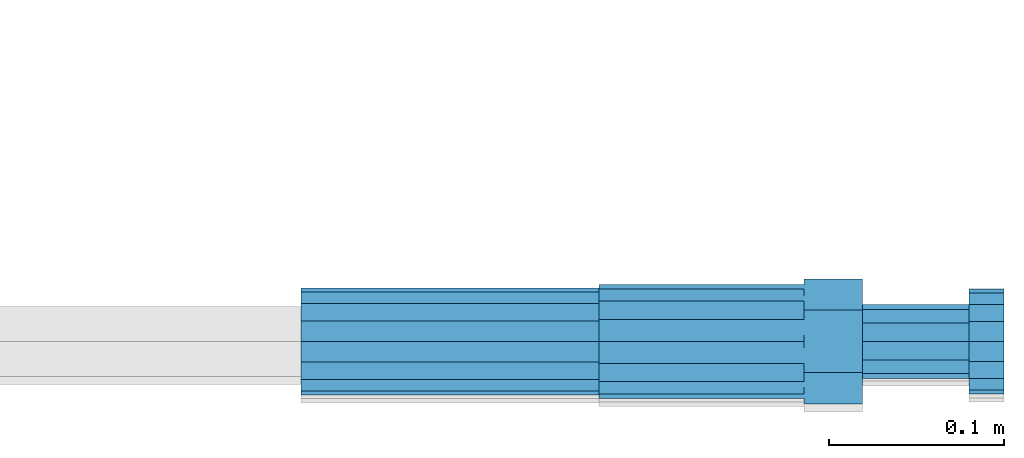
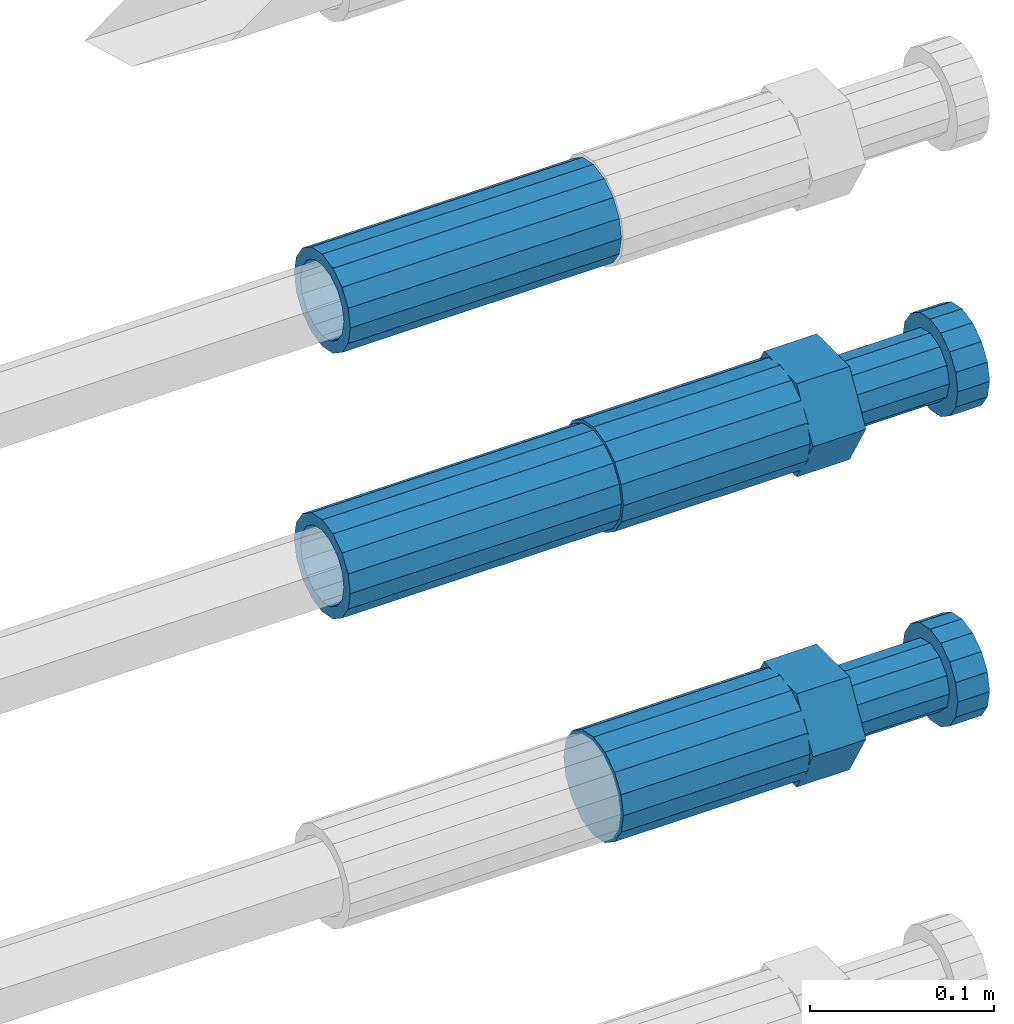
# One storey, part 106 of 119: 4 beams.
"""IFC2X3 building model written with IfcOpenShell, lengths in millimetres."""

import ifcopenshell
import ifcopenshell.guid

model = None  # the IFC model being written
_history = None  # IfcOwnerHistory: only IFC2X3 demands one
_inside = {}  # id of a spatial element -> (the spatial element, [elements in it])
_under = {}  # id of a project, library or spatial element -> (it, [spatial elements below it])
_declared = {}  # id of a project -> (the project, [libraries it declares])
_typed = {}  # id of a type object -> (the type object, [elements of that type])
_made_of = {}  # id of a material, layer set ... -> (it, [elements and type objects made of it])


def new_model(schema):
    """Start an empty IFC model of exactly this schema.

    Asked for "IFC4X3", IfcOpenShell would pick the latest addendum, in which some entities
    have other attributes; the version numbers below select the first issue.
    IFC2X3 requires an IfcOwnerHistory on every rooted entity: one is made here for all.
    """
    global model, _history
    if schema == "IFC4X3":
        model = ifcopenshell.file(schema_version=(4, 3, 0, 0))
    else:
        model = ifcopenshell.file(schema=schema)
    _inside.clear()
    _under.clear()
    _declared.clear()
    _typed.clear()
    _made_of.clear()
    _history = None
    if model.schema == "IFC2X3":
        org = make("IfcOrganization", Name="unknown")
        user = make(
            "IfcPersonAndOrganization",
            ThePerson=make("IfcPerson", FamilyName="unknown"),
            TheOrganization=org,
        )
        app = make(
            "IfcApplication",
            ApplicationDeveloper=org,
            Version="unknown",
            ApplicationFullName="unknown",
            ApplicationIdentifier="unknown",
        )
        _history = make(
            "IfcOwnerHistory",
            OwningUser=user,
            OwningApplication=app,
            ChangeAction="ADDED",
            CreationDate=0,
        )
    return model


def make(cls, **values):
    """One entity of the class cls with the attributes given. An attribute that is None is left unset."""
    return model.create_entity(
        cls, **{name: value for name, value in values.items() if value is not None}
    )


def rooted(cls, **values):
    """An entity with a GlobalId (a new one), such as an element, a storey or a relation."""
    return make(cls, GlobalId=ifcopenshell.guid.new(), OwnerHistory=_history, **values)


def si_unit(unit_type, name, prefix=None):
    """IfcSIUnit, for example si_unit("LENGTHUNIT", "METRE", prefix="MILLI")."""
    return make("IfcSIUnit", UnitType=unit_type, Prefix=prefix, Name=name)


def assignment(units):
    """IfcUnitAssignment: the units of a project."""
    return None if units is None else make("IfcUnitAssignment", Units=units)


def point(xyz):
    """IfcCartesianPoint."""
    return None if xyz is None else make("IfcCartesianPoint", Coordinates=xyz)


def direction(xyz):
    """IfcDirection."""
    return None if xyz is None else make("IfcDirection", DirectionRatios=xyz)


def frame(location, z_axis=None, x_axis=None):
    """IfcAxis2Placement3D, a coordinate frame: its origin and axes. An axis left out is left unset."""
    return make(
        "IfcAxis2Placement3D",
        Location=point(location),
        Axis=direction(z_axis),
        RefDirection=direction(x_axis),
    )


def origin_with_axes():
    """The frame at (0, 0, 0) with the z axis (0, 0, 1) and the x axis (1, 0, 0) written out."""
    return frame((0.0, 0.0, 0.0), z_axis=(0.0, 0.0, 1.0), x_axis=(1.0, 0.0, 0.0))


def place(relative_to, where):
    """IfcLocalPlacement: puts the frame where relative to a parent placement (None: the world)."""
    return make(
        "IfcLocalPlacement", PlacementRelTo=relative_to, RelativePlacement=where
    )


def context(
    kind, dimensions, precision=None, world=None, true_north=None, identifier=None
):
    """IfcGeometricRepresentationContext, for example the 3D "Model" context."""
    return make(
        "IfcGeometricRepresentationContext",
        ContextIdentifier=identifier,
        ContextType=kind,
        CoordinateSpaceDimension=dimensions,
        Precision=precision,
        WorldCoordinateSystem=world,
        TrueNorth=true_north,
    )


def subcontext(parent, identifier, kind, view, scale=None):
    """IfcGeometricRepresentationSubContext, for example "Body" below "Model"."""
    return make(
        "IfcGeometricRepresentationSubContext",
        ContextIdentifier=identifier,
        ContextType=kind,
        ParentContext=parent,
        TargetScale=scale,
        TargetView=view,
    )


def project(units=None, contexts=None):
    """IfcProject with its units and contexts."""
    return rooted(
        "IfcProject",
        Name="project",
        RepresentationContexts=contexts,
        UnitsInContext=assignment(units),
    )


def spatial(cls, under=None, at=None, **own):
    """A site, building, storey or space (cls), placed at a placement, below another one or the project."""
    s = rooted(cls, ObjectPlacement=at, **own)
    if under is not None:
        _under.setdefault(under.id(), (under, []))[1].append(s)
    return s


def faces_of(points, faces, orient=None, outer=None):
    """IfcFace entities. A face is a list of loops; a loop is a list of indices into points, from 0.

    orient and outer hold one flag for each loop. By default every Orientation is true, the
    first loop of a face is its IfcFaceOuterBound and the others are IfcFaceBound.
    """
    made = []
    for i, loops in enumerate(faces):
        bounds = []
        for j, loop in enumerate(loops):
            is_outer = j == 0 if outer is None else outer[i][j]
            bounds.append(
                make(
                    "IfcFaceOuterBound" if is_outer else "IfcFaceBound",
                    Bound=make("IfcPolyLoop", Polygon=[points[k] for k in loop]),
                    Orientation=True if orient is None else orient[i][j],
                )
            )
        made.append(make("IfcFace", Bounds=bounds))
    return made


def faceted_brep(points, faces, orient=None, outer=None, voids=None):
    """IfcFacetedBrep: a solid bounded by flat faces; with voids (closed shells), ...WithVoids."""
    shared = [point(p) for p in points]
    hull = make("IfcClosedShell", CfsFaces=faces_of(shared, faces, orient, outer))
    if voids is None:
        return make("IfcFacetedBrep", Outer=hull)
    return make(
        "IfcFacetedBrepWithVoids",
        Outer=hull,
        Voids=[
            make(cls, CfsFaces=faces_of(shared, fs, o, b)) for cls, fs, o, b in voids
        ],
    )


def shape(context_of_items, identifier, shape_type, items):
    """IfcShapeRepresentation: the items that make up one representation, for example the "Body"."""
    return make(
        "IfcShapeRepresentation",
        ContextOfItems=context_of_items,
        RepresentationIdentifier=identifier,
        RepresentationType=shape_type,
        Items=items,
    )


def material(Name=None, Category=None):
    """IfcMaterial."""
    return make("IfcMaterial", Name=Name, Category=Category)


def made_of(thing, what):
    """Note that an element or type object is made of a material, layer set ...; save() writes the relation."""
    if what is not None:
        _made_of.setdefault(what.id(), (what, []))[1].append(thing)
    return thing


def type_object(cls, material=None, **own):
    """A type object (cls), such as IfcWallType, which elements share."""
    return made_of(rooted(cls, **own), material)


def element(
    cls,
    number,
    at=None,
    inside=None,
    cuts=None,
    type_object=None,
    material=None,
    context=None,
    identifier="Body",
    shape_type=None,
    held_by="IfcProductDefinitionShape",
    body=None,
    shapes=None,
    **own,
):
    """One element of the class cls, such as IfcWall. Its Tag is "e" and its number.

    at: its placement. inside: the storey or other place that contains it. cuts: it is an
    opening in that element (IfcRelVoidsElement). A single representation is given by context,
    identifier, shape_type and body (its items); several are given by shapes. held_by: the class
    of the entity that holds the representations. save() writes the other relations.
    """
    e = rooted(cls, Tag="e%d" % number, ObjectPlacement=at, **own)
    if body is not None:
        shapes = [shape(context, identifier, shape_type, body)]
    if shapes is not None:
        e.Representation = make(held_by, Representations=shapes)
    if inside is not None:
        _inside.setdefault(inside.id(), (inside, []))[1].append(e)
    if cuts is not None:
        rooted(
            "IfcRelVoidsElement", RelatingBuildingElement=cuts, RelatedOpeningElement=e
        )
    if type_object is not None:
        _typed.setdefault(type_object.id(), (type_object, []))[1].append(e)
    return made_of(e, material)


def aggregate(whole, parts):
    """IfcRelAggregates: a whole, such as a stair, and the parts it consists of."""
    return rooted("IfcRelAggregates", RelatingObject=whole, RelatedObjects=parts)


def save(model, path):
    """Write the relations noted so far, then the file.

    IfcRelAggregates (storeys below a building ...), IfcRelContainedInSpatialStructure (elements
    in a storey), IfcRelDefinesByType, IfcRelAssociatesMaterial and IfcRelDeclares: one each for
    every whole, place, type object, material and project.
    """
    for whole, parts in _under.values():
        aggregate(whole, parts)
    for where, things in _inside.values():
        rooted(
            "IfcRelContainedInSpatialStructure",
            RelatedElements=things,
            RelatingStructure=where,
        )
    for kind, things in _typed.values():
        rooted("IfcRelDefinesByType", RelatedObjects=things, RelatingType=kind)
    for what, things in _made_of.values():
        rooted("IfcRelAssociatesMaterial", RelatedObjects=things, RelatingMaterial=what)
    for by, libraries in _declared.values():
        rooted("IfcRelDeclares", RelatingContext=by, RelatedDefinitions=libraries)
    model.write(path)


model = new_model("IFC2X3")

# Units and contexts
model_context = context("Model", 3, precision=1e-05, world=origin_with_axes())
body_context = subcontext(model_context, "Body", "Model", "MODEL_VIEW")
ifc_project = project(units=[si_unit("LENGTHUNIT", "METRE", prefix="MILLI"), si_unit("AREAUNIT", "SQUARE_METRE"), si_unit("VOLUMEUNIT", "CUBIC_METRE"), si_unit("MASSUNIT", "GRAM", prefix="KILO"), si_unit("TIMEUNIT", "SECOND"), si_unit("PLANEANGLEUNIT", "RADIAN"), si_unit("SOLIDANGLEUNIT", "STERADIAN"), si_unit("THERMODYNAMICTEMPERATUREUNIT", "DEGREE_CELSIUS"), si_unit("LUMINOUSINTENSITYUNIT", "LUMEN")], contexts=[model_context])

# Site, building, storey
site_placement = place(None, origin_with_axes())
site = spatial("IfcSite", under=ifc_project, at=site_placement, CompositionType="ELEMENT")
building_placement = place(site_placement, origin_with_axes())
building = spatial("IfcBuilding", under=site, at=building_placement, Name="Undefined", CompositionType="ELEMENT")
storey_placement = place(building_placement, origin_with_axes())
storey = spatial("IfcBuildingStorey", under=building, at=storey_placement, Name="Undefined", CompositionType="ELEMENT", Elevation=0.0)

# Beams
ifc_material = material(Name="STEEL/S275")
beam_type_1 = type_object("IfcBeamType", PredefinedType="NOTDEFINED")
beam_1_placement = place(storey_placement, frame((2039349.03023304, 6205102.98994599, 21913.4694122944), z_axis=(0.0, 0.0, 1.0), x_axis=(1.0, 0.0, 0.0)))
element("IfcBeam", 1, at=beam_1_placement, inside=storey, type_object=beam_type_1, material=ifc_material, Name="AG40N", context=body_context, shape_type="Brep", body=[
    faceted_brep([(1.62981450557709e-09, -23.4999999990687, 0.0), (7.45058059692383e-09, -21.7111690142192, 8.99306066057534), (170.000002125278, -21.711168999318, 8.99306066022245), (170.000002127141, -23.4999999844003, -3.66071617463604e-10), (4.65661287307739e-09, -16.6170093587134, 16.6170093578889), (170.000002122484, -16.6170093440451, 16.6170093575288), (1.86264514923096e-09, -8.99306066217832, 21.7111690140277), (170.000002118759, -8.99306064750999, 21.7111690136603), (2.3283064365387e-10, 9.31322574615479e-10, 23.5), (170.000002114102, 1.28056854009628e-08, 23.4999999996485), (-6.51925802230835e-09, 8.99306065868586, 21.7111690140241), (170.00000211224, 8.99306067335419, 21.7111690136639), (-7.45058059692383e-09, 16.6170093561523, 16.6170093578853), (170.000002109446, 16.6170093708206, 16.6170093575324), (-9.31322574615479e-09, 21.711169013055, 8.99306066057534), (170.000002108514, 21.7111690277234, 8.99306066022245), (-1.16415321826935e-09, 23.5000000009313, 0.0), (170.000002108514, 23.5000000144355, -3.66071617463604e-10), (-8.38190317153931e-09, 21.7111690151505, -8.99306066059444), (170.000002110377, 21.7111690300517, -8.9930606609546), (-5.58793544769287e-09, 16.6170093598776, -16.6170093579008), (170.000002113171, 16.6170093745459, -16.6170093582609), (-9.31322574615479e-10, 8.99306066334248, -21.7111690140396), (170.000002115965, 8.99306067801081, -21.7111690143961), (2.3283064365387e-10, 9.31322574615479e-10, -23.5), (170.00000211969, 1.7927959561348e-08, -23.5000000003843), (5.58793544769287e-09, -8.99306065752171, -21.7111690140396), (170.000002123415, -8.99306064285338, -21.7111690143961), (8.38190317153931e-09, -16.6170093549881, -16.6170093579008), (170.000002125278, -16.6170093403198, -16.6170093582646), (9.31322574615479e-09, -21.7111690121237, -8.99306066059444), (170.000002127141, -21.7111689972226, -8.9930606609546), (1.11758708953857e-08, -30.4999999990687, -9.54969436861575e-12), (1.30385160446167e-08, -28.1783257392235, -11.6718446871514), (170.000002129003, -28.1783257243223, -11.6718446875116), (170.000002129935, -30.4999999841675, -3.66071617463604e-10), (1.02445483207703e-08, -21.5667568228673, -21.5667568262129), (170.000002128072, -21.566756808199, -21.5667568265694), (7.45058059692383e-09, -11.6718446831219, -28.1783257416196), (170.000002125278, -11.6718446684536, -28.1783257419834), (3.72529029846191e-09, 3.95812094211578e-09, -30.5000000000277), (170.00000211969, 1.83936208486557e-08, -30.5000000003879), (-9.31322574615479e-10, 11.6718446905725, -28.1783257416232), (170.000002115965, 11.6718447052408, -28.1783257419797), (-6.51925802230835e-09, 21.5667568286881, -21.5667568262093), (170.000002110377, 21.5667568433564, -21.5667568265694), (-9.31322574615479e-09, 28.178325742716, -11.6718446871478), (170.000002108514, 28.1783257573843, -11.6718446875079), (-1.21071934700012e-08, 30.5, -5.91171556152403e-12), (170.000002106652, 30.5000000144355, -3.62433638656512e-10), (-1.21071934700012e-08, 28.1783257401548, 11.6718446871359), (170.00000210572, 28.1783257548232, 11.6718446867794), (-1.02445483207703e-08, 21.5667568240315, 21.5667568261974), (170.000002107583, 21.566756838467, 21.5667568258409), (-7.45058059692383e-09, 11.671844684286, 28.1783257416041), (170.000002110377, 11.6718446989544, 28.178325741244), (-2.79396772384644e-09, -2.56113708019257e-09, 30.5000000000159), (170.000002114102, 1.18743628263474e-08, 30.4999999996558), (1.86264514923096e-09, -11.6718446896411, 28.1783257416114), (170.000002118759, -11.67184467474, 28.178325741244), (7.45058059692383e-09, -21.5667568275239, 21.5667568261974), (170.000002123415, -21.5667568126228, 21.5667568258373), (1.02445483207703e-08, -28.1783257415518, 11.6718446871359), (170.000002127141, -28.1783257271163, 11.6718446867794)], [[[0, 1, 2, 3]], [[1, 4, 5, 2]], [[4, 6, 7, 5]], [[6, 8, 9, 7]], [[8, 10, 11, 9]], [[10, 12, 13, 11]], [[12, 14, 15, 13]], [[14, 16, 17, 15]], [[16, 18, 19, 17]], [[18, 20, 21, 19]], [[20, 22, 23, 21]], [[22, 24, 25, 23]], [[24, 26, 27, 25]], [[26, 28, 29, 27]], [[28, 30, 31, 29]], [[30, 0, 3, 31]], [[32, 33, 34, 35]], [[33, 36, 37, 34]], [[36, 38, 39, 37]], [[38, 40, 41, 39]], [[40, 42, 43, 41]], [[42, 44, 45, 43]], [[44, 46, 47, 45]], [[46, 48, 49, 47]], [[48, 50, 51, 49]], [[50, 52, 53, 51]], [[52, 54, 55, 53]], [[54, 56, 57, 55]], [[56, 58, 59, 57]], [[58, 60, 61, 59]], [[60, 62, 63, 61]], [[62, 32, 35, 63]], [[37, 39, 41, 43, 45, 47, 49, 51, 53, 55, 57, 59, 61, 63, 35, 34], [5, 7, 9, 11, 13, 15, 17, 19, 21, 23, 25, 27, 29, 31, 3, 2]], [[62, 60, 58, 56, 54, 52, 50, 48, 46, 44, 42, 40, 38, 36, 33, 32], [30, 28, 26, 24, 22, 20, 18, 16, 14, 12, 10, 8, 6, 4, 1, 0]]]),
])
beam_2_placement = place(storey_placement, frame((2039349.03023304, 6205102.98994599, 22089.4694122944), z_axis=(0.0, 0.0, 1.0), x_axis=(1.0, 0.0, 0.0)))
element("IfcBeam", 2, at=beam_2_placement, inside=storey, type_object=beam_type_1, material=ifc_material, Name="AG40N", context=body_context, shape_type="Brep", body=[
    faceted_brep([(1.62981450557709e-09, -23.4999999990687, 0.0), (7.45058059692383e-09, -21.7111690142192, 8.99306066057534), (170.000002125278, -21.711168999318, 8.99306066022245), (170.000002127141, -23.4999999844003, -3.66071617463604e-10), (4.65661287307739e-09, -16.6170093587134, 16.6170093578889), (170.000002122484, -16.6170093440451, 16.6170093575288), (1.86264514923096e-09, -8.99306066217832, 21.7111690140277), (170.000002118759, -8.99306064750999, 21.7111690136603), (2.3283064365387e-10, 9.31322574615479e-10, 23.5), (170.000002114102, 1.28056854009628e-08, 23.4999999996485), (-6.51925802230835e-09, 8.99306065868586, 21.7111690140241), (170.00000211224, 8.99306067335419, 21.7111690136639), (-7.45058059692383e-09, 16.6170093561523, 16.6170093578853), (170.000002109446, 16.6170093708206, 16.6170093575324), (-9.31322574615479e-09, 21.711169013055, 8.99306066057534), (170.000002108514, 21.7111690277234, 8.99306066022245), (-1.16415321826935e-09, 23.5000000009313, 0.0), (170.000002108514, 23.5000000144355, -3.66071617463604e-10), (-8.38190317153931e-09, 21.7111690151505, -8.99306066059444), (170.000002110377, 21.7111690300517, -8.9930606609546), (-5.58793544769287e-09, 16.6170093598776, -16.6170093579008), (170.000002113171, 16.6170093745459, -16.6170093582609), (-9.31322574615479e-10, 8.99306066334248, -21.7111690140396), (170.000002115965, 8.99306067801081, -21.7111690143961), (2.3283064365387e-10, 9.31322574615479e-10, -23.5), (170.00000211969, 1.7927959561348e-08, -23.5000000003843), (5.58793544769287e-09, -8.99306065752171, -21.7111690140396), (170.000002123415, -8.99306064285338, -21.7111690143961), (8.38190317153931e-09, -16.6170093549881, -16.6170093579008), (170.000002125278, -16.6170093403198, -16.6170093582646), (9.31322574615479e-09, -21.7111690121237, -8.99306066059444), (170.000002127141, -21.7111689972226, -8.9930606609546), (1.11758708953857e-08, -30.4999999990687, -9.54969436861575e-12), (1.30385160446167e-08, -28.1783257392235, -11.6718446871514), (170.000002129003, -28.1783257243223, -11.6718446875116), (170.000002129935, -30.4999999841675, -3.66071617463604e-10), (1.02445483207703e-08, -21.5667568228673, -21.5667568262129), (170.000002128072, -21.566756808199, -21.5667568265694), (7.45058059692383e-09, -11.6718446831219, -28.1783257416196), (170.000002125278, -11.6718446684536, -28.1783257419834), (3.72529029846191e-09, 3.95812094211578e-09, -30.5000000000277), (170.00000211969, 1.83936208486557e-08, -30.5000000003879), (-9.31322574615479e-10, 11.6718446905725, -28.1783257416232), (170.000002115965, 11.6718447052408, -28.1783257419797), (-6.51925802230835e-09, 21.5667568286881, -21.5667568262093), (170.000002110377, 21.5667568433564, -21.5667568265694), (-9.31322574615479e-09, 28.178325742716, -11.6718446871478), (170.000002108514, 28.1783257573843, -11.6718446875079), (-1.21071934700012e-08, 30.5, -5.91171556152403e-12), (170.000002106652, 30.5000000144355, -3.62433638656512e-10), (-1.21071934700012e-08, 28.1783257401548, 11.6718446871359), (170.00000210572, 28.1783257548232, 11.6718446867794), (-1.02445483207703e-08, 21.5667568240315, 21.5667568261974), (170.000002107583, 21.566756838467, 21.5667568258409), (-7.45058059692383e-09, 11.671844684286, 28.1783257416041), (170.000002110377, 11.6718446989544, 28.178325741244), (-2.79396772384644e-09, -2.56113708019257e-09, 30.5000000000159), (170.000002114102, 1.18743628263474e-08, 30.4999999996558), (1.86264514923096e-09, -11.6718446896411, 28.1783257416114), (170.000002118759, -11.67184467474, 28.178325741244), (7.45058059692383e-09, -21.5667568275239, 21.5667568261974), (170.000002123415, -21.5667568126228, 21.5667568258373), (1.02445483207703e-08, -28.1783257415518, 11.6718446871359), (170.000002127141, -28.1783257271163, 11.6718446867794)], [[[0, 1, 2, 3]], [[1, 4, 5, 2]], [[4, 6, 7, 5]], [[6, 8, 9, 7]], [[8, 10, 11, 9]], [[10, 12, 13, 11]], [[12, 14, 15, 13]], [[14, 16, 17, 15]], [[16, 18, 19, 17]], [[18, 20, 21, 19]], [[20, 22, 23, 21]], [[22, 24, 25, 23]], [[24, 26, 27, 25]], [[26, 28, 29, 27]], [[28, 30, 31, 29]], [[30, 0, 3, 31]], [[32, 33, 34, 35]], [[33, 36, 37, 34]], [[36, 38, 39, 37]], [[38, 40, 41, 39]], [[40, 42, 43, 41]], [[42, 44, 45, 43]], [[44, 46, 47, 45]], [[46, 48, 49, 47]], [[48, 50, 51, 49]], [[50, 52, 53, 51]], [[52, 54, 55, 53]], [[54, 56, 57, 55]], [[56, 58, 59, 57]], [[58, 60, 61, 59]], [[60, 62, 63, 61]], [[62, 32, 35, 63]], [[37, 39, 41, 43, 45, 47, 49, 51, 53, 55, 57, 59, 61, 63, 35, 34], [5, 7, 9, 11, 13, 15, 17, 19, 21, 23, 25, 27, 29, 31, 3, 2]], [[62, 60, 58, 56, 54, 52, 50, 48, 46, 44, 42, 40, 38, 36, 33, 32], [30, 28, 26, 24, 22, 20, 18, 16, 14, 12, 10, 8, 6, 4, 1, 0]]]),
])
beam_type_2 = type_object("IfcBeamType", Name="ROD65", PredefinedType="NOTDEFINED")
beam_3_placement = place(storey_placement, frame((2039519.03023304, 6205102.98994599, 21707.9894143809), z_axis=(0.0, 0.0, 1.0), x_axis=(1.0, 0.0, 0.0)))
element("IfcBeam", 3, at=beam_3_placement, inside=storey, type_object=beam_type_2, material=ifc_material, Name="AGB40", ObjectType="ROD65", context=body_context, shape_type="Brep", body=[
    faceted_brep([(116.999999999069, 17.8249999252148, 30.8738056446964), (116.999999998137, 22.0056957420893, 23.632628078838), (116.999999999069, 12.4372115600854, 30.0260848066173), (116.999999999069, 8.17543111252598, 30.8738056446964), (117.000000000931, -17.8250000746921, 30.8738056446964), (150.200000001118, -17.8250000723638, 30.8738056446964), (150.199999999255, 17.8249999275431, 30.8738056446964), (117.000000000931, -8.17543109622784, 30.8738056446964), (117.000000001863, -22.0056959956419, 23.6326278985034), (117.000000000931, -12.4372115437873, 30.0260848066173), (117.000000001863, -35.6500000746455, -2.18278728425503e-10), (150.200000002049, -35.6500000723172, -2.18278728425503e-10), (117.000000001863, -30.8443149488885, 8.32369080289209), (117.000000001863, -30.8443149488885, -8.32369080355784), (117.000000002794, -32.4999999918509, 0.0), (117.000000000931, -17.8250000746921, -30.873805645133), (150.200000001118, -17.8250000723638, -30.873805645133), (117.000000001863, -22.0056959961075, -23.6326278982269), (117.000000000931, -8.17543109389953, -30.873805645133), (117.000000000931, -12.4372115437873, -30.0260848066173), (116.999999999069, 17.8249999252148, -30.873805645133), (150.199999999255, 17.8249999275431, -30.873805645133), (116.999999999069, 8.17543111019768, -30.873805645133), (116.999999999069, 12.4372115600854, -30.0260848066173), (116.999999998137, 22.005695742555, -23.6326280785652), (116.999999998137, 35.6499999251682, -2.18278728425503e-10), (150.199999998324, 35.6499999277294, -2.18278728425503e-10), (116.999999998137, 30.8443150522653, -8.32369036550881), (116.999999997206, 32.5000000081491, 0.0), (116.999999998137, 30.8443150522653, 8.32369036483942), (1.86264514923096e-09, -22.9809703885112, 22.9809703885621), (1.86264514923096e-09, -30.0260848065373, 12.4372115518672), (117.000000001863, -30.0260847983882, 12.4372115518672), (117.000000001863, -22.9809703803621, 22.9809703885621), (-1.86264514923096e-09, 22.9809703885112, -22.9809703885621), (-1.86264514923096e-09, 30.0260848065373, -12.4372115518672), (116.999999998137, 30.0260848146863, -12.4372115518672), (116.999999998137, 22.9809703966603, -22.9809703885621), (1.86264514923096e-09, -30.0260848065373, -12.4372115518672), (1.86264514923096e-09, -22.9809703885112, -22.9809703885621), (117.000000001863, -22.9809703803621, -22.9809703885621), (117.000000001863, -30.0260847983882, -12.4372115518672), (9.31322574615479e-10, -12.4372115519363, 30.0260848066173), (0.0, 0.0, 32.5), (-9.31322574615479e-10, 12.4372115519363, 30.0260848066173), (-1.86264514923096e-09, 22.9809703885112, 22.9809703885621), (-1.86264514923096e-09, 30.0260848065373, 12.4372115518672), (-2.79396772384644e-09, 32.5, 0.0), (-9.31322574615479e-10, 12.4372115519363, -30.0260848066173), (0.0, 0.0, -32.5), (9.31322574615479e-10, -12.4372115519363, -30.0260848066173), (2.79396772384644e-09, -32.5, 0.0), (116.999999998137, 22.9809703966603, 22.9809703885621), (116.999999998137, 30.0260848146863, 12.4372115518672), (117.0, 8.14907252788544e-09, -32.5), (117.0, 8.14907252788544e-09, 32.5), (150.200000000186, -10.5000000959262, 18.1865334791873), (150.199999999255, -9.59262251853943e-08, 20.9999999997126), (150.199999998324, 10.4999999040738, 18.1865334791873), (150.199999997392, 18.1865333835594, 10.4999999997126), (150.199999997392, 20.9999999040738, -2.87400325760245e-10), (150.199999997392, 18.1865333835594, -10.5000000002874), (150.199999998324, 10.4999999040738, -18.1865334797621), (150.199999999255, -9.59262251853943e-08, -21.0000000002874), (150.200000000186, -10.5000000959262, -18.1865334797621), (150.200000000186, -18.1865335754119, -10.5000000002874), (150.200000001118, -21.0000000959262, -2.87400325760245e-10), (150.200000000186, -18.1865335754119, 10.4999999997126), (210.979999999516, 10.4999999082647, 18.1865334791873), (210.979999999516, -9.17352735996246e-08, 20.9999999997126), (210.979999997653, 18.1865333877504, 10.4999999997126), (210.979999997653, 20.9999999082647, -2.87400325760245e-10), (210.979999997653, 18.1865333877504, -10.5000000002874), (210.979999999516, 10.4999999082647, -18.1865334797621), (210.979999999516, -9.17352735996246e-08, -21.0000000002874), (210.979999999516, -10.5000000917353, -18.1865334797621), (210.980000000447, -18.1865335712209, -10.5000000002874), (210.980000001378, -21.0000000917353, -2.87400325760245e-10), (210.980000000447, -18.1865335712209, 10.4999999997126), (210.979999999516, -10.5000000917353, 18.1865334791873), (211.001368402503, -27.7269939335529, -11.4911163272045), (211.003082515672, -21.2238095656503, -21.2238154190527), (231.002518340945, -21.2131946226582, -21.2132004554769), (231.000804228708, -27.7163789905608, -11.4805013636287), (211.001368415542, -11.4911086384673, -27.7269970399575), (231.000804241747, -11.4804936954752, -27.7163820763781), (210.996487061493, -0.0106066407170147, -30.0106107396168), (230.995922887698, 8.30227509140968e-06, -29.999995776041), (210.98918159306, 11.4698940692469, -27.7269970332745), (230.988617419265, 11.4805090120062, -27.7163820696951), (210.980564201251, 21.2025913291145, -21.2238154067054), (230.980000027455, 21.2132062721066, -21.2132004431296), (210.971946807578, 27.7057702087332, -11.4911163110701), (230.971382633783, 27.7163851517253, -11.4805013474943), (210.964641331695, 29.9893806746695, -0.0106149565435771), (230.9640771579, 29.9999956176616, 7.03221303410828e-09), (210.959759964608, 27.7057637346443, 11.4698863966551), (230.959195790812, 27.7163786776364, 11.4805013602345), (210.958045851439, 21.2025793667417, 21.2025854885032), (230.957481677644, 21.2131943097338, 21.2132004520827), (210.959759951569, 11.4698784395587, 27.705767109408), (230.959195776843, 11.4804933823179, 27.7163820729838), (210.964641305618, -0.0106235581915826, 29.9893808090674), (230.964077131823, -8.61519947648048e-06, 29.9999957726432), (210.971946774051, -11.4911242681555, 27.7057671027251), (230.971382599324, -11.4805093251634, 27.7163820663009), (210.98056416586, -21.2238215280231, 21.2025854761559), (230.979999991134, -21.2132065852638, 21.2132004397354), (210.989181559533, -27.7270004076418, 11.4698863805206), (230.988617384806, -27.7163854646496, 11.4805013441), (210.996487035416, -30.0106108735781, -0.0106149740058754), (230.995922861621, -29.999995930586, -1.04300852399319e-08)], [[[0, 1, 2, 3]], [[4, 5, 6, 0, 3, 7]], [[8, 4, 7, 9]], [[10, 11, 5, 4, 8, 12]], [[13, 10, 12, 14]], [[15, 16, 11, 10, 13, 17]], [[18, 15, 17, 19]], [[20, 21, 16, 15, 18, 22]], [[20, 22, 23, 24]], [[25, 26, 21, 20, 24, 27]], [[25, 27, 28, 29]], [[30, 31, 32, 33]], [[34, 35, 36, 37]], [[38, 39, 40, 41]], [[31, 30, 42, 43, 44, 45, 46, 47, 35, 34, 48, 49, 50, 39, 38, 51]], [[46, 45, 52, 53]], [[28, 47, 46, 53, 29]], [[27, 36, 35, 47, 28]], [[24, 37, 36, 27]], [[23, 48, 34, 37, 24]], [[22, 54, 49, 48, 23]], [[18, 54, 22]], [[19, 50, 49, 54, 18]], [[17, 40, 39, 50, 19]], [[13, 41, 40, 17]], [[14, 51, 38, 41, 13]], [[12, 32, 31, 51, 14]], [[8, 33, 32, 12]], [[9, 42, 30, 33, 8]], [[7, 55, 43, 42, 9]], [[3, 55, 7]], [[2, 44, 43, 55, 3]], [[1, 52, 45, 44, 2]], [[29, 53, 52, 1]], [[0, 6, 26, 25, 29, 1]], [[5, 11, 16, 21, 26, 6], [56, 57, 58, 59, 60, 61, 62, 63, 64, 65, 66, 67]], [[68, 58, 57, 69]], [[70, 59, 58, 68]], [[71, 60, 59, 70]], [[72, 61, 60, 71]], [[73, 62, 61, 72]], [[74, 63, 62, 73]], [[75, 64, 63, 74]], [[76, 65, 64, 75]], [[77, 66, 65, 76]], [[78, 67, 66, 77]], [[79, 56, 67, 78]], [[69, 57, 56, 79]], [[80, 81, 82, 83]], [[81, 84, 85, 82]], [[84, 86, 87, 85]], [[86, 88, 89, 87]], [[88, 90, 91, 89]], [[90, 92, 93, 91]], [[92, 94, 95, 93]], [[94, 96, 97, 95]], [[96, 98, 99, 97]], [[98, 100, 101, 99]], [[100, 102, 103, 101]], [[102, 104, 105, 103]], [[104, 106, 107, 105]], [[106, 108, 109, 107]], [[108, 110, 111, 109]], [[82, 85, 87, 89, 91, 93, 95, 97, 99, 101, 103, 105, 107, 109, 111, 83]], [[110, 80, 83, 111]], [[108, 106, 104, 102, 100, 98, 96, 94, 92, 90, 88, 86, 84, 81, 80, 110], [78, 77, 76, 75, 74, 73, 72, 71, 70, 68, 69, 79]]]),
])
beam_4_placement = place(storey_placement, frame((2039519.03023304, 6205102.98994599, 21913.4694143809), z_axis=(0.0, 0.0, 1.0), x_axis=(1.0, 0.0, 0.0)))
element("IfcBeam", 4, at=beam_4_placement, inside=storey, type_object=beam_type_2, material=ifc_material, Name="AGB40", ObjectType="ROD65", context=body_context, shape_type="Brep", body=[
    faceted_brep([(116.999999999069, 17.8249999252148, 30.8738056446964), (116.999999998137, 22.0056957420893, 23.632628078838), (116.999999999069, 12.4372115600854, 30.0260848066173), (116.999999999069, 8.17543111252598, 30.8738056446964), (117.000000000931, -17.8250000746921, 30.8738056446964), (150.200000001118, -17.8250000723638, 30.8738056446964), (150.199999999255, 17.8249999275431, 30.8738056446964), (117.000000000931, -8.17543109622784, 30.8738056446964), (117.000000001863, -22.0056959956419, 23.6326278985034), (117.000000000931, -12.4372115437873, 30.0260848066173), (117.000000001863, -35.6500000746455, -2.18278728425503e-10), (150.200000002049, -35.6500000723172, -2.18278728425503e-10), (117.000000001863, -30.8443149488885, 8.32369080289209), (117.000000001863, -30.8443149488885, -8.32369080355784), (117.000000002794, -32.4999999918509, 0.0), (117.000000000931, -17.8250000746921, -30.873805645133), (150.200000001118, -17.8250000723638, -30.873805645133), (117.000000001863, -22.0056959961075, -23.6326278982269), (117.000000000931, -8.17543109389953, -30.873805645133), (117.000000000931, -12.4372115437873, -30.0260848066173), (116.999999999069, 17.8249999252148, -30.873805645133), (150.199999999255, 17.8249999275431, -30.873805645133), (116.999999999069, 8.17543111019768, -30.873805645133), (116.999999999069, 12.4372115600854, -30.0260848066173), (116.999999998137, 22.005695742555, -23.6326280785652), (116.999999998137, 35.6499999251682, -2.18278728425503e-10), (150.199999998324, 35.6499999277294, -2.18278728425503e-10), (116.999999998137, 30.8443150522653, -8.32369036550881), (116.999999997206, 32.5000000081491, 0.0), (116.999999998137, 30.8443150522653, 8.32369036483942), (1.86264514923096e-09, -22.9809703885112, 22.9809703885621), (1.86264514923096e-09, -30.0260848065373, 12.4372115518672), (117.000000001863, -30.0260847983882, 12.4372115518672), (117.000000001863, -22.9809703803621, 22.9809703885621), (-1.86264514923096e-09, 22.9809703885112, -22.9809703885621), (-1.86264514923096e-09, 30.0260848065373, -12.4372115518672), (116.999999998137, 30.0260848146863, -12.4372115518672), (116.999999998137, 22.9809703966603, -22.9809703885621), (1.86264514923096e-09, -30.0260848065373, -12.4372115518672), (1.86264514923096e-09, -22.9809703885112, -22.9809703885621), (117.000000001863, -22.9809703803621, -22.9809703885621), (117.000000001863, -30.0260847983882, -12.4372115518672), (9.31322574615479e-10, -12.4372115519363, 30.0260848066173), (0.0, 0.0, 32.5), (-9.31322574615479e-10, 12.4372115519363, 30.0260848066173), (-1.86264514923096e-09, 22.9809703885112, 22.9809703885621), (-1.86264514923096e-09, 30.0260848065373, 12.4372115518672), (-2.79396772384644e-09, 32.5, 0.0), (-9.31322574615479e-10, 12.4372115519363, -30.0260848066173), (0.0, 0.0, -32.5), (9.31322574615479e-10, -12.4372115519363, -30.0260848066173), (2.79396772384644e-09, -32.5, 0.0), (116.999999998137, 22.9809703966603, 22.9809703885621), (116.999999998137, 30.0260848146863, 12.4372115518672), (117.0, 8.14907252788544e-09, -32.5), (117.0, 8.14907252788544e-09, 32.5), (150.200000000186, -10.5000000959262, 18.1865334791873), (150.199999999255, -9.59262251853943e-08, 20.9999999997126), (150.199999998324, 10.4999999040738, 18.1865334791873), (150.199999997392, 18.1865333835594, 10.4999999997126), (150.199999997392, 20.9999999040738, -2.87400325760245e-10), (150.199999997392, 18.1865333835594, -10.5000000002874), (150.199999998324, 10.4999999040738, -18.1865334797621), (150.199999999255, -9.59262251853943e-08, -21.0000000002874), (150.200000000186, -10.5000000959262, -18.1865334797621), (150.200000000186, -18.1865335754119, -10.5000000002874), (150.200000001118, -21.0000000959262, -2.87400325760245e-10), (150.200000000186, -18.1865335754119, 10.4999999997126), (210.979999999516, 10.4999999082647, 18.1865334791873), (210.979999999516, -9.17352735996246e-08, 20.9999999997126), (210.979999997653, 18.1865333877504, 10.4999999997126), (210.979999997653, 20.9999999082647, -2.87400325760245e-10), (210.979999997653, 18.1865333877504, -10.5000000002874), (210.979999999516, 10.4999999082647, -18.1865334797621), (210.979999999516, -9.17352735996246e-08, -21.0000000002874), (210.979999999516, -10.5000000917353, -18.1865334797621), (210.980000000447, -18.1865335712209, -10.5000000002874), (210.980000001378, -21.0000000917353, -2.87400325760245e-10), (210.980000000447, -18.1865335712209, 10.4999999997126), (210.979999999516, -10.5000000917353, 18.1865334791873), (211.001368402503, -27.7269939335529, -11.4911163272045), (211.003082515672, -21.2238095656503, -21.2238154190527), (231.002518340945, -21.2131946226582, -21.2132004554769), (231.000804228708, -27.7163789905608, -11.4805013636287), (211.001368415542, -11.4911086384673, -27.7269970399575), (231.000804241747, -11.4804936954752, -27.7163820763781), (210.996487061493, -0.0106066407170147, -30.0106107396168), (230.995922887698, 8.30227509140968e-06, -29.999995776041), (210.98918159306, 11.4698940692469, -27.7269970332745), (230.988617419265, 11.4805090120062, -27.7163820696951), (210.980564201251, 21.2025913291145, -21.2238154067054), (230.980000027455, 21.2132062721066, -21.2132004431296), (210.971946807578, 27.7057702087332, -11.4911163110701), (230.971382633783, 27.7163851517253, -11.4805013474943), (210.964641331695, 29.9893806746695, -0.0106149565435771), (230.9640771579, 29.9999956176616, 7.03221303410828e-09), (210.959759964608, 27.7057637346443, 11.4698863966551), (230.959195790812, 27.7163786776364, 11.4805013602345), (210.958045851439, 21.2025793667417, 21.2025854885032), (230.957481677644, 21.2131943097338, 21.2132004520827), (210.959759951569, 11.4698784395587, 27.705767109408), (230.959195776843, 11.4804933823179, 27.7163820729838), (210.964641305618, -0.0106235581915826, 29.9893808090674), (230.964077131823, -8.61519947648048e-06, 29.9999957726432), (210.971946774051, -11.4911242681555, 27.7057671027251), (230.971382599324, -11.4805093251634, 27.7163820663009), (210.98056416586, -21.2238215280231, 21.2025854761559), (230.979999991134, -21.2132065852638, 21.2132004397354), (210.989181559533, -27.7270004076418, 11.4698863805206), (230.988617384806, -27.7163854646496, 11.4805013441), (210.996487035416, -30.0106108735781, -0.0106149740058754), (230.995922861621, -29.999995930586, -1.04300852399319e-08)], [[[0, 1, 2, 3]], [[4, 5, 6, 0, 3, 7]], [[8, 4, 7, 9]], [[10, 11, 5, 4, 8, 12]], [[13, 10, 12, 14]], [[15, 16, 11, 10, 13, 17]], [[18, 15, 17, 19]], [[20, 21, 16, 15, 18, 22]], [[20, 22, 23, 24]], [[25, 26, 21, 20, 24, 27]], [[25, 27, 28, 29]], [[30, 31, 32, 33]], [[34, 35, 36, 37]], [[38, 39, 40, 41]], [[31, 30, 42, 43, 44, 45, 46, 47, 35, 34, 48, 49, 50, 39, 38, 51]], [[46, 45, 52, 53]], [[28, 47, 46, 53, 29]], [[27, 36, 35, 47, 28]], [[24, 37, 36, 27]], [[23, 48, 34, 37, 24]], [[22, 54, 49, 48, 23]], [[18, 54, 22]], [[19, 50, 49, 54, 18]], [[17, 40, 39, 50, 19]], [[13, 41, 40, 17]], [[14, 51, 38, 41, 13]], [[12, 32, 31, 51, 14]], [[8, 33, 32, 12]], [[9, 42, 30, 33, 8]], [[7, 55, 43, 42, 9]], [[3, 55, 7]], [[2, 44, 43, 55, 3]], [[1, 52, 45, 44, 2]], [[29, 53, 52, 1]], [[0, 6, 26, 25, 29, 1]], [[5, 11, 16, 21, 26, 6], [56, 57, 58, 59, 60, 61, 62, 63, 64, 65, 66, 67]], [[68, 58, 57, 69]], [[70, 59, 58, 68]], [[71, 60, 59, 70]], [[72, 61, 60, 71]], [[73, 62, 61, 72]], [[74, 63, 62, 73]], [[75, 64, 63, 74]], [[76, 65, 64, 75]], [[77, 66, 65, 76]], [[78, 67, 66, 77]], [[79, 56, 67, 78]], [[69, 57, 56, 79]], [[80, 81, 82, 83]], [[81, 84, 85, 82]], [[84, 86, 87, 85]], [[86, 88, 89, 87]], [[88, 90, 91, 89]], [[90, 92, 93, 91]], [[92, 94, 95, 93]], [[94, 96, 97, 95]], [[96, 98, 99, 97]], [[98, 100, 101, 99]], [[100, 102, 103, 101]], [[102, 104, 105, 103]], [[104, 106, 107, 105]], [[106, 108, 109, 107]], [[108, 110, 111, 109]], [[82, 85, 87, 89, 91, 93, 95, 97, 99, 101, 103, 105, 107, 109, 111, 83]], [[110, 80, 83, 111]], [[108, 106, 104, 102, 100, 98, 96, 94, 92, 90, 88, 86, 84, 81, 80, 110], [78, 77, 76, 75, 74, 73, 72, 71, 70, 68, 69, 79]]]),
])

save(model, "model.ifc")
